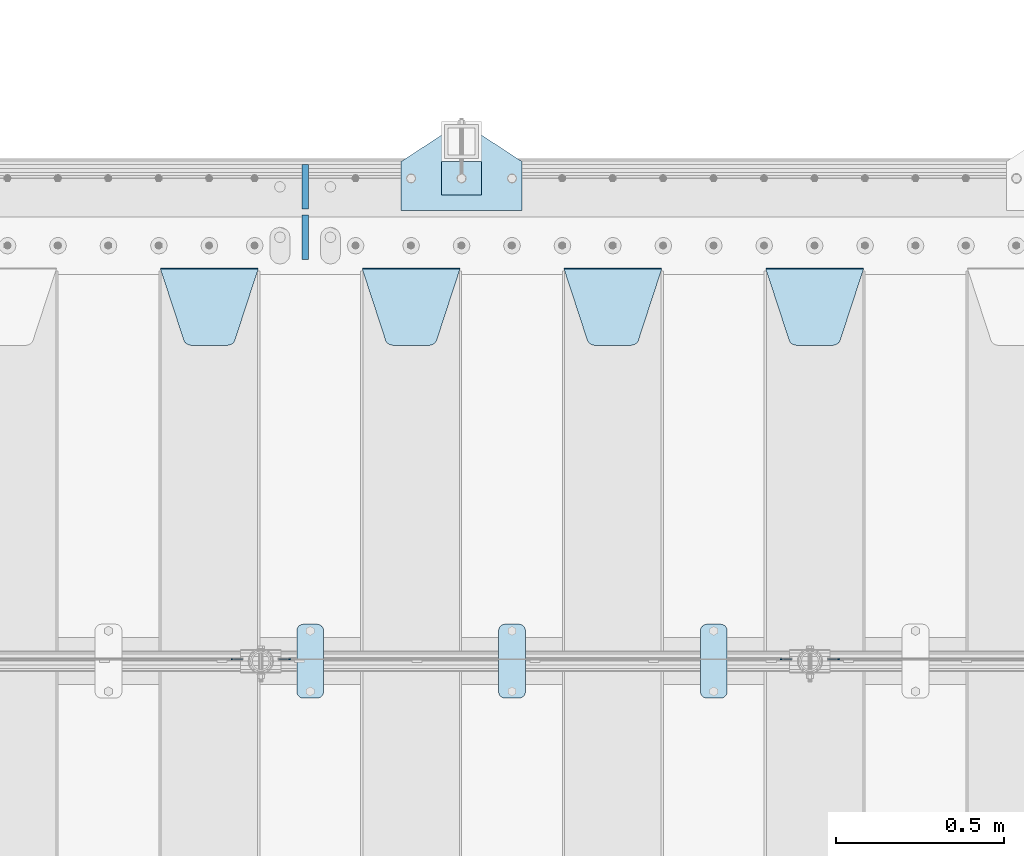
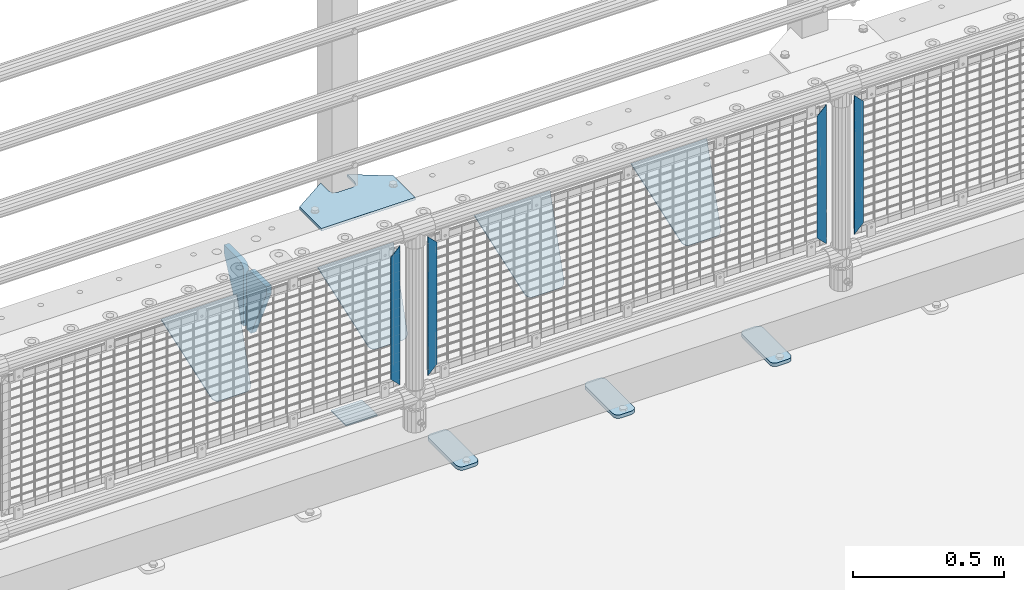
# One storey, part 234 of 270: 15 plates.
"""IFC2X3 building model written with IfcOpenShell, lengths in millimetres."""

from ifc_helpers import new_model, si_unit, frame, origin_with_axes, place, context, subcontext, project, spatial, faceted_brep, material, type_object, element, save


model = new_model("IFC2X3")

# Units and contexts
model_context = context("Model", 3, precision=1e-05, world=origin_with_axes())
body_context = subcontext(model_context, "Body", "Model", "MODEL_VIEW")
ifc_project = project(units=[si_unit("LENGTHUNIT", "METRE", prefix="MILLI"), si_unit("AREAUNIT", "SQUARE_METRE"), si_unit("VOLUMEUNIT", "CUBIC_METRE"), si_unit("MASSUNIT", "GRAM", prefix="KILO"), si_unit("TIMEUNIT", "SECOND"), si_unit("PLANEANGLEUNIT", "RADIAN"), si_unit("SOLIDANGLEUNIT", "STERADIAN"), si_unit("THERMODYNAMICTEMPERATUREUNIT", "DEGREE_CELSIUS"), si_unit("LUMINOUSINTENSITYUNIT", "LUMEN")], contexts=[model_context])

# Site, building, storey
site_placement = place(None, origin_with_axes())
site = spatial("IfcSite", under=ifc_project, at=site_placement, CompositionType="ELEMENT")
building_placement = place(site_placement, origin_with_axes())
building = spatial("IfcBuilding", under=site, at=building_placement, Name="Standard", CompositionType="ELEMENT")
storey_placement = place(building_placement, origin_with_axes())
storey = spatial("IfcBuildingStorey", under=building, at=storey_placement, Name="Undefined", CompositionType="ELEMENT", Elevation=0.0)

# Plates
ifc_material_1 = material(Name="STEEL/S355J2")
plate_type_1 = type_object("IfcPlateType", PredefinedType="NOTDEFINED")
plate_1_placement = place(storey_placement, frame((7570.0, -14995.0, 5.00000000004911), z_axis=(0.0, 1.0, 0.0), x_axis=(1.0, 0.0, 0.0)))
element("IfcPlate", 1, at=plate_1_placement, inside=storey, type_object=plate_type_1, material=ifc_material_1, context=body_context, shape_type="Brep", body=[
    faceted_brep([(0.0, -5.0, 0.0), (2.31396552408114e-06, -5.0, 145.0), (2.31396552408114e-06, 5.0, 145.0), (0.0, 5.0, 0.0), (130.0, -5.0, 230.0), (130.0, 5.0, 230.0), (130.0, -5.0, 180.0), (130.0, 5.0, 180.0), (130.48036798992, -5.0, 175.122741949597), (130.48036798992, 5.0, 175.122741949597), (131.903011687216, -5.0, 170.432914190873), (131.903011687216, 5.0, 170.432914190873), (134.213259692435, -5.0, 166.11074417451), (134.213259692435, 5.0, 166.11074417451), (137.322330470335, -5.0, 162.322330470337), (137.322330470335, 5.0, 162.322330470337), (141.110744174512, -5.0, 159.213259692437), (141.110744174512, 5.0, 159.213259692437), (145.432914190871, -5.0, 156.903011687218), (145.432914190871, 5.0, 156.903011687218), (150.122741949595, -5.0, 155.48036798992), (150.122741949595, 5.0, 155.48036798992), (155.0, -5.0, 155.0), (155.0, 5.0, 155.0), (205.0, -5.0, 155.0), (205.0, 5.0, 155.0), (209.877258050405, -5.0, 155.48036798992), (209.877258050405, 5.0, 155.48036798992), (214.567085809129, -5.0, 156.903011687218), (214.567085809129, 5.0, 156.903011687218), (218.889255825488, -5.0, 159.213259692437), (218.889255825488, 5.0, 159.213259692437), (222.677669529665, -5.0, 162.322330470337), (222.677669529665, 5.0, 162.322330470337), (225.786740307565, -5.0, 166.11074417451), (225.786740307565, 5.0, 166.11074417451), (228.096988312784, -5.0, 170.432914190873), (228.096988312784, 5.0, 170.432914190873), (229.51963201008, -5.0, 175.122741949597), (229.51963201008, 5.0, 175.122741949597), (230.0, -5.0, 180.0), (230.0, 5.0, 180.0), (230.0, -5.0, 230.0), (230.0, 5.0, 230.0), (360.0, -5.0, 145.0), (360.0, 5.0, 145.0), (360.0, -5.0, -7.27595761418343e-12), (360.0, 5.0, -7.27595761418343e-12)], [[[0, 1, 2, 3]], [[1, 4, 5, 2]], [[4, 6, 7, 5]], [[6, 8, 9, 7]], [[8, 10, 11, 9]], [[10, 12, 13, 11]], [[12, 14, 15, 13]], [[14, 16, 17, 15]], [[16, 18, 19, 17]], [[18, 20, 21, 19]], [[20, 22, 23, 21]], [[22, 24, 25, 23]], [[24, 26, 27, 25]], [[26, 28, 29, 27]], [[28, 30, 31, 29]], [[30, 32, 33, 31]], [[32, 34, 35, 33]], [[34, 36, 37, 35]], [[36, 38, 39, 37]], [[38, 40, 41, 39]], [[40, 42, 43, 41]], [[42, 44, 45, 43]], [[44, 46, 47, 45]], [[46, 0, 3, 47]], [[5, 7, 9, 11, 13, 15, 17, 19, 21, 23, 25, 27, 29, 31, 33, 35, 37, 39, 41, 43, 45, 47, 3, 2]], [[46, 44, 42, 40, 38, 36, 34, 32, 30, 28, 26, 24, 22, 20, 18, 16, 14, 12, 10, 8, 6, 4, 1, 0]]]),
])
plate_type_2 = type_object("IfcPlateType", PredefinedType="NOTDEFINED")
plate_2_placement = place(storey_placement, frame((7690.00000000014, -14949.9999999998, -857.500000000002), z_axis=(0.0, 1.0, 0.0), x_axis=(1.0, 0.0, 0.0)))
element("IfcPlate", 2, at=plate_2_placement, inside=storey, type_object=plate_type_2, material=ifc_material_1, context=body_context, shape_type="Brep", body=[
    faceted_brep([(0.0, -2.5, 0.0), (0.0, -2.5, 100.0), (0.0, 2.5, 100.0), (0.0, 2.5, 0.0), (120.0, -2.5, 100.0), (120.0, 2.5, 100.0), (120.0, -2.5, 0.0), (120.0, 2.5, 0.0)], [[[0, 1, 2, 3]], [[1, 4, 5, 2]], [[4, 6, 7, 5]], [[6, 0, 3, 7]], [[5, 7, 3, 2]], [[6, 4, 1, 0]]]),
])
plate_type_3 = type_object("IfcPlateType", PredefinedType="NOTDEFINED")
plate_3_placement = place(storey_placement, frame((8460.0, -16225.5, 21.0199999999977), z_axis=(1.0, 0.0, 0.0), x_axis=(0.0, -1.0, 0.0)))
element("IfcPlate", 3, at=plate_3_placement, inside=storey, type_object=plate_type_3, material=ifc_material_1, context=body_context, shape_type="Brep", body=[
    faceted_brep([(0.0, -7.0, 20.0), (0.0, -7.0, 60.0), (0.0, 7.0, 60.0), (0.0, 7.0, 20.0), (0.384294391937146, -7.0, 63.9018064403208), (0.384294391937146, 7.0, 63.9018064403208), (1.52240934977453, -7.0, 67.6536686473009), (1.52240934977453, 7.0, 67.6536686473009), (3.37060775395003, -7.0, 71.1114046603907), (3.37060775395003, 7.0, 71.1114046603907), (5.8578643762703, -7.0, 74.1421356237297), (5.8578643762703, 7.0, 74.1421356237297), (8.88859533960931, -7.0, 76.62939224605), (8.88859533960931, 7.0, 76.62939224605), (12.3463313526991, -7.0, 78.4775906502255), (12.3463313526991, 7.0, 78.4775906502255), (16.0981935596792, -7.0, 79.6157056080629), (16.0981935596792, 7.0, 79.6157056080629), (20.0, -7.0, 80.0), (20.0, 7.0, 80.0), (200.0, -7.0, 80.0), (200.0, 7.0, 80.0), (203.901806440321, -7.0, 79.6157056080629), (203.901806440321, 7.0, 79.6157056080629), (207.653668647301, -7.0, 78.4775906502255), (207.653668647301, 7.0, 78.4775906502255), (211.111404660391, -7.0, 76.62939224605), (211.111404660391, 7.0, 76.62939224605), (214.142135623733, -7.0, 74.1421356237297), (214.142135623733, 7.0, 74.1421356237297), (216.629392246054, -7.0, 71.1114046603907), (216.629392246054, 7.0, 71.1114046603907), (218.477590650225, -7.0, 67.6536686473009), (218.477590650225, 7.0, 67.6536686473009), (219.615705608063, -7.0, 63.9018064403208), (219.615705608063, 7.0, 63.9018064403208), (220.0, -7.0, 60.0), (220.0, 7.0, 60.0), (220.0, -7.0, 20.0), (220.0, 7.0, 20.0), (219.615705608063, -7.0, 16.0981935596792), (219.615705608063, 7.0, 16.0981935596792), (218.477590650225, -7.0, 12.3463313526991), (218.477590650225, 7.0, 12.3463313526991), (216.629392246054, -7.0, 8.88859533960931), (216.629392246054, 7.0, 8.88859533960931), (214.142135623733, -7.0, 5.8578643762703), (214.142135623733, 7.0, 5.8578643762703), (211.111404660391, -7.0, 3.37060775395003), (211.111404660391, 7.0, 3.37060775395003), (207.653668647301, -7.0, 1.52240934977453), (207.653668647301, 7.0, 1.52240934977453), (203.901806440321, -7.0, 0.384294391937146), (203.901806440321, 7.0, 0.384294391937146), (200.0, -7.0, 0.0), (200.0, 7.0, 0.0), (20.0, -7.0, 0.0), (20.0, 7.0, 0.0), (16.0981935596792, -7.0, 0.384294391937146), (16.0981935596792, 7.0, 0.384294391937146), (12.3463313526991, -7.0, 1.52240934977453), (12.3463313526991, 7.0, 1.52240934977453), (8.88859533960931, -7.0, 3.37060775395003), (8.88859533960931, 7.0, 3.37060775395003), (5.8578643762703, -7.0, 5.8578643762703), (5.8578643762703, 7.0, 5.8578643762703), (3.37060775395003, -7.0, 8.88859533960931), (3.37060775395003, 7.0, 8.88859533960931), (1.52240934977453, -7.0, 12.3463313526991), (1.52240934977453, 7.0, 12.3463313526991), (0.384294391937146, -7.0, 16.0981935596792), (0.384294391937146, 7.0, 16.0981935596792)], [[[0, 1, 2, 3]], [[1, 4, 5, 2]], [[4, 6, 7, 5]], [[6, 8, 9, 7]], [[8, 10, 11, 9]], [[10, 12, 13, 11]], [[12, 14, 15, 13]], [[14, 16, 17, 15]], [[16, 18, 19, 17]], [[18, 20, 21, 19]], [[20, 22, 23, 21]], [[22, 24, 25, 23]], [[24, 26, 27, 25]], [[26, 28, 29, 27]], [[28, 30, 31, 29]], [[30, 32, 33, 31]], [[32, 34, 35, 33]], [[34, 36, 37, 35]], [[36, 38, 39, 37]], [[38, 40, 41, 39]], [[40, 42, 43, 41]], [[42, 44, 45, 43]], [[44, 46, 47, 45]], [[46, 48, 49, 47]], [[48, 50, 51, 49]], [[50, 52, 53, 51]], [[52, 54, 55, 53]], [[54, 56, 57, 55]], [[56, 58, 59, 57]], [[58, 60, 61, 59]], [[60, 62, 63, 61]], [[62, 64, 65, 63]], [[64, 66, 67, 65]], [[66, 68, 69, 67]], [[68, 70, 71, 69]], [[70, 0, 3, 71]], [[5, 7, 9, 11, 13, 15, 17, 19, 21, 23, 25, 27, 29, 31, 33, 35, 37, 39, 41, 43, 45, 47, 49, 51, 53, 55, 57, 59, 61, 63, 65, 67, 69, 71, 3, 2]], [[70, 68, 66, 64, 62, 60, 58, 56, 54, 52, 50, 48, 46, 44, 42, 40, 38, 36, 34, 32, 30, 28, 26, 24, 22, 20, 18, 16, 14, 12, 10, 8, 6, 4, 1, 0]]]),
])
plate_4_placement = place(storey_placement, frame((7860.0, -16225.5, 21.0199999999977), z_axis=(1.0, 0.0, 0.0), x_axis=(0.0, -1.0, 0.0)))
element("IfcPlate", 4, at=plate_4_placement, inside=storey, type_object=plate_type_3, material=ifc_material_1, context=body_context, shape_type="Brep", body=[
    faceted_brep([(0.0, -7.0, 20.0), (0.0, -7.0, 60.0), (0.0, 7.0, 60.0), (0.0, 7.0, 20.0), (0.384294391937146, -7.0, 63.9018064403208), (0.384294391937146, 7.0, 63.9018064403208), (1.52240934977453, -7.0, 67.6536686473009), (1.52240934977453, 7.0, 67.6536686473009), (3.37060775395003, -7.0, 71.1114046603907), (3.37060775395003, 7.0, 71.1114046603907), (5.8578643762703, -7.0, 74.1421356237297), (5.8578643762703, 7.0, 74.1421356237297), (8.88859533960931, -7.0, 76.62939224605), (8.88859533960931, 7.0, 76.62939224605), (12.3463313526991, -7.0, 78.4775906502255), (12.3463313526991, 7.0, 78.4775906502255), (16.0981935596792, -7.0, 79.6157056080629), (16.0981935596792, 7.0, 79.6157056080629), (20.0, -7.0, 80.0), (20.0, 7.0, 80.0), (200.0, -7.0, 80.0), (200.0, 7.0, 80.0), (203.901806440321, -7.0, 79.6157056080629), (203.901806440321, 7.0, 79.6157056080629), (207.653668647301, -7.0, 78.4775906502255), (207.653668647301, 7.0, 78.4775906502255), (211.111404660391, -7.0, 76.62939224605), (211.111404660391, 7.0, 76.62939224605), (214.142135623733, -7.0, 74.1421356237297), (214.142135623733, 7.0, 74.1421356237297), (216.629392246054, -7.0, 71.1114046603907), (216.629392246054, 7.0, 71.1114046603907), (218.477590650225, -7.0, 67.6536686473009), (218.477590650225, 7.0, 67.6536686473009), (219.615705608063, -7.0, 63.9018064403208), (219.615705608063, 7.0, 63.9018064403208), (220.0, -7.0, 60.0), (220.0, 7.0, 60.0), (220.0, -7.0, 20.0), (220.0, 7.0, 20.0), (219.615705608063, -7.0, 16.0981935596792), (219.615705608063, 7.0, 16.0981935596792), (218.477590650225, -7.0, 12.3463313526991), (218.477590650225, 7.0, 12.3463313526991), (216.629392246054, -7.0, 8.88859533960931), (216.629392246054, 7.0, 8.88859533960931), (214.142135623733, -7.0, 5.8578643762703), (214.142135623733, 7.0, 5.8578643762703), (211.111404660391, -7.0, 3.37060775395003), (211.111404660391, 7.0, 3.37060775395003), (207.653668647301, -7.0, 1.52240934977453), (207.653668647301, 7.0, 1.52240934977453), (203.901806440321, -7.0, 0.384294391937146), (203.901806440321, 7.0, 0.384294391937146), (200.0, -7.0, 0.0), (200.0, 7.0, 0.0), (20.0, -7.0, 0.0), (20.0, 7.0, 0.0), (16.0981935596792, -7.0, 0.384294391937146), (16.0981935596792, 7.0, 0.384294391937146), (12.3463313526991, -7.0, 1.52240934977453), (12.3463313526991, 7.0, 1.52240934977453), (8.88859533960931, -7.0, 3.37060775395003), (8.88859533960931, 7.0, 3.37060775395003), (5.8578643762703, -7.0, 5.8578643762703), (5.8578643762703, 7.0, 5.8578643762703), (3.37060775395003, -7.0, 8.88859533960931), (3.37060775395003, 7.0, 8.88859533960931), (1.52240934977453, -7.0, 12.3463313526991), (1.52240934977453, 7.0, 12.3463313526991), (0.384294391937146, -7.0, 16.0981935596792), (0.384294391937146, 7.0, 16.0981935596792)], [[[0, 1, 2, 3]], [[1, 4, 5, 2]], [[4, 6, 7, 5]], [[6, 8, 9, 7]], [[8, 10, 11, 9]], [[10, 12, 13, 11]], [[12, 14, 15, 13]], [[14, 16, 17, 15]], [[16, 18, 19, 17]], [[18, 20, 21, 19]], [[20, 22, 23, 21]], [[22, 24, 25, 23]], [[24, 26, 27, 25]], [[26, 28, 29, 27]], [[28, 30, 31, 29]], [[30, 32, 33, 31]], [[32, 34, 35, 33]], [[34, 36, 37, 35]], [[36, 38, 39, 37]], [[38, 40, 41, 39]], [[40, 42, 43, 41]], [[42, 44, 45, 43]], [[44, 46, 47, 45]], [[46, 48, 49, 47]], [[48, 50, 51, 49]], [[50, 52, 53, 51]], [[52, 54, 55, 53]], [[54, 56, 57, 55]], [[56, 58, 59, 57]], [[58, 60, 61, 59]], [[60, 62, 63, 61]], [[62, 64, 65, 63]], [[64, 66, 67, 65]], [[66, 68, 69, 67]], [[68, 70, 71, 69]], [[70, 0, 3, 71]], [[5, 7, 9, 11, 13, 15, 17, 19, 21, 23, 25, 27, 29, 31, 33, 35, 37, 39, 41, 43, 45, 47, 49, 51, 53, 55, 57, 59, 61, 63, 65, 67, 69, 71, 3, 2]], [[70, 68, 66, 64, 62, 60, 58, 56, 54, 52, 50, 48, 46, 44, 42, 40, 38, 36, 34, 32, 30, 28, 26, 24, 22, 20, 18, 16, 14, 12, 10, 8, 6, 4, 1, 0]]]),
])
plate_5_placement = place(storey_placement, frame((7260.0, -16225.5, 21.0199999999977), z_axis=(1.0, 0.0, 0.0), x_axis=(0.0, -1.0, 0.0)))
element("IfcPlate", 5, at=plate_5_placement, inside=storey, type_object=plate_type_3, material=ifc_material_1, context=body_context, shape_type="Brep", body=[
    faceted_brep([(0.0, -7.0, 20.0), (0.0, -7.0, 60.0), (0.0, 7.0, 60.0), (0.0, 7.0, 20.0), (0.384294391937146, -7.0, 63.9018064403208), (0.384294391937146, 7.0, 63.9018064403208), (1.52240934977453, -7.0, 67.6536686473009), (1.52240934977453, 7.0, 67.6536686473009), (3.37060775395003, -7.0, 71.1114046603907), (3.37060775395003, 7.0, 71.1114046603907), (5.8578643762703, -7.0, 74.1421356237297), (5.8578643762703, 7.0, 74.1421356237297), (8.88859533960931, -7.0, 76.62939224605), (8.88859533960931, 7.0, 76.62939224605), (12.3463313526991, -7.0, 78.4775906502255), (12.3463313526991, 7.0, 78.4775906502255), (16.0981935596792, -7.0, 79.6157056080629), (16.0981935596792, 7.0, 79.6157056080629), (20.0, -7.0, 80.0), (20.0, 7.0, 80.0), (200.0, -7.0, 80.0), (200.0, 7.0, 80.0), (203.901806440321, -7.0, 79.6157056080629), (203.901806440321, 7.0, 79.6157056080629), (207.653668647301, -7.0, 78.4775906502255), (207.653668647301, 7.0, 78.4775906502255), (211.111404660391, -7.0, 76.62939224605), (211.111404660391, 7.0, 76.62939224605), (214.142135623733, -7.0, 74.1421356237297), (214.142135623733, 7.0, 74.1421356237297), (216.629392246054, -7.0, 71.1114046603907), (216.629392246054, 7.0, 71.1114046603907), (218.477590650225, -7.0, 67.6536686473009), (218.477590650225, 7.0, 67.6536686473009), (219.615705608063, -7.0, 63.9018064403208), (219.615705608063, 7.0, 63.9018064403208), (220.0, -7.0, 60.0), (220.0, 7.0, 60.0), (220.0, -7.0, 20.0), (220.0, 7.0, 20.0), (219.615705608063, -7.0, 16.0981935596792), (219.615705608063, 7.0, 16.0981935596792), (218.477590650225, -7.0, 12.3463313526991), (218.477590650225, 7.0, 12.3463313526991), (216.629392246054, -7.0, 8.88859533960931), (216.629392246054, 7.0, 8.88859533960931), (214.142135623733, -7.0, 5.8578643762703), (214.142135623733, 7.0, 5.8578643762703), (211.111404660391, -7.0, 3.37060775395003), (211.111404660391, 7.0, 3.37060775395003), (207.653668647301, -7.0, 1.52240934977453), (207.653668647301, 7.0, 1.52240934977453), (203.901806440321, -7.0, 0.384294391937146), (203.901806440321, 7.0, 0.384294391937146), (200.0, -7.0, 0.0), (200.0, 7.0, 0.0), (20.0, -7.0, 0.0), (20.0, 7.0, 0.0), (16.0981935596792, -7.0, 0.384294391937146), (16.0981935596792, 7.0, 0.384294391937146), (12.3463313526991, -7.0, 1.52240934977453), (12.3463313526991, 7.0, 1.52240934977453), (8.88859533960931, -7.0, 3.37060775395003), (8.88859533960931, 7.0, 3.37060775395003), (5.8578643762703, -7.0, 5.8578643762703), (5.8578643762703, 7.0, 5.8578643762703), (3.37060775395003, -7.0, 8.88859533960931), (3.37060775395003, 7.0, 8.88859533960931), (1.52240934977453, -7.0, 12.3463313526991), (1.52240934977453, 7.0, 12.3463313526991), (0.384294391937146, -7.0, 16.0981935596792), (0.384294391937146, 7.0, 16.0981935596792)], [[[0, 1, 2, 3]], [[1, 4, 5, 2]], [[4, 6, 7, 5]], [[6, 8, 9, 7]], [[8, 10, 11, 9]], [[10, 12, 13, 11]], [[12, 14, 15, 13]], [[14, 16, 17, 15]], [[16, 18, 19, 17]], [[18, 20, 21, 19]], [[20, 22, 23, 21]], [[22, 24, 25, 23]], [[24, 26, 27, 25]], [[26, 28, 29, 27]], [[28, 30, 31, 29]], [[30, 32, 33, 31]], [[32, 34, 35, 33]], [[34, 36, 37, 35]], [[36, 38, 39, 37]], [[38, 40, 41, 39]], [[40, 42, 43, 41]], [[42, 44, 45, 43]], [[44, 46, 47, 45]], [[46, 48, 49, 47]], [[48, 50, 51, 49]], [[50, 52, 53, 51]], [[52, 54, 55, 53]], [[54, 56, 57, 55]], [[56, 58, 59, 57]], [[58, 60, 61, 59]], [[60, 62, 63, 61]], [[62, 64, 65, 63]], [[64, 66, 67, 65]], [[66, 68, 69, 67]], [[68, 70, 71, 69]], [[70, 0, 3, 71]], [[5, 7, 9, 11, 13, 15, 17, 19, 21, 23, 25, 27, 29, 31, 33, 35, 37, 39, 41, 43, 45, 47, 49, 51, 53, 55, 57, 59, 61, 63, 65, 67, 69, 71, 3, 2]], [[70, 68, 66, 64, 62, 60, 58, 56, 54, 52, 50, 48, 46, 44, 42, 40, 38, 36, 34, 32, 30, 28, 26, 24, 22, 20, 18, 16, 14, 12, 10, 8, 6, 4, 1, 0]]]),
])
ifc_material_2 = material(Name="STEEL/S355N")
plate_type_4 = type_object("IfcPlateType", PredefinedType="NOTDEFINED")
plate_6_placement = place(storey_placement, frame((8655.0, -15168.2322330441, -1.76776695296576), z_axis=(0.0, -0.707106781186548, -0.707106781186547), x_axis=(1.0, 0.0, 0.0)))
element("IfcPlate", 6, at=plate_6_placement, inside=storey, type_object=plate_type_4, material=ifc_material_2, context=body_context, shape_type="Brep", body=[
    faceted_brep([(0.0, -2.5, 0.0), (69.345504679477, -2.5, 300.171731424831), (69.345504679477, 2.5, 300.171731424831), (0.0, 2.5, 0.0), (70.9274061199576, -2.5, 304.8974424154), (70.9274061199576, 2.5, 304.8974424154), (73.3818627772307, -2.49999999999818, 309.234538108527), (73.3818627772307, 2.50000000000182, 309.234538108527), (76.6187032999551, -2.5, 313.023683126103), (76.6187032999551, 2.5, 313.023683126103), (80.5190132704993, -2.5, 316.125672595372), (80.5190132704993, 2.50000000000182, 316.125672595372), (84.9395038596849, -2.49999999999818, 318.426546230476), (84.9395038596849, 2.5, 318.426546230476), (89.7177759439219, -2.49999999999818, 319.841774983275), (89.7177759439219, 2.50000000000182, 319.841774983275), (94.678286292652, -2.5, 320.319366455078), (94.678286292652, 2.5, 320.319366455078), (195.321713707348, -2.5, 320.319366455078), (195.321713707348, 2.5, 320.319366455078), (200.282224056078, -2.49999999999818, 319.841774983275), (200.282224056078, 2.50000000000182, 319.841774983275), (205.060496140315, -2.5, 318.426546230476), (205.060496140315, 2.5, 318.426546230476), (209.480986729501, -2.5, 316.12567259537), (209.480986729501, 2.50000000000182, 316.12567259537), (213.381296700045, -2.5, 313.023683126103), (213.381296700045, 2.5, 313.023683126103), (216.618137222769, -2.49999999999818, 309.234538108525), (216.618137222769, 2.50000000000182, 309.234538108527), (219.072593880042, -2.49999999999818, 304.897442415398), (219.072593880042, 2.50000000000182, 304.897442415397), (220.654495320523, -2.5, 300.171731424831), (220.654495320523, 2.5, 300.171731424831), (290.0, -2.49999999999818, 0.0), (290.0, 2.5, 0.0)], [[[0, 1, 2, 3]], [[1, 4, 5, 2]], [[4, 6, 7, 5]], [[6, 8, 9, 7]], [[8, 10, 11, 9]], [[10, 12, 13, 11]], [[12, 14, 15, 13]], [[14, 16, 17, 15]], [[16, 18, 19, 17]], [[18, 20, 21, 19]], [[20, 22, 23, 21]], [[22, 24, 25, 23]], [[24, 26, 27, 25]], [[26, 28, 29, 27]], [[28, 30, 31, 29]], [[30, 32, 33, 31]], [[32, 34, 35, 33]], [[34, 0, 3, 35]], [[5, 7, 9, 11, 13, 15, 17, 19, 21, 23, 25, 27, 29, 31, 33, 35, 3, 2]], [[34, 32, 30, 28, 26, 24, 22, 20, 18, 16, 14, 12, 10, 8, 6, 4, 1, 0]]]),
])
plate_7_placement = place(storey_placement, frame((8055.0, -15168.2322330441, -1.76776695296576), z_axis=(0.0, -0.707106781186548, -0.707106781186547), x_axis=(1.0, 0.0, 0.0)))
element("IfcPlate", 7, at=plate_7_placement, inside=storey, type_object=plate_type_4, material=ifc_material_2, context=body_context, shape_type="Brep", body=[
    faceted_brep([(0.0, -2.5, 0.0), (69.345504679477, -2.5, 300.171731424831), (69.345504679477, 2.5, 300.171731424831), (0.0, 2.5, 0.0), (70.9274061199576, -2.5, 304.8974424154), (70.9274061199576, 2.5, 304.8974424154), (73.3818627772307, -2.49999999999818, 309.234538108527), (73.3818627772307, 2.50000000000182, 309.234538108527), (76.6187032999551, -2.5, 313.023683126103), (76.6187032999551, 2.5, 313.023683126103), (80.5190132704993, -2.5, 316.125672595372), (80.5190132704993, 2.50000000000182, 316.125672595372), (84.9395038596849, -2.49999999999818, 318.426546230476), (84.9395038596849, 2.5, 318.426546230476), (89.7177759439219, -2.49999999999818, 319.841774983275), (89.7177759439219, 2.50000000000182, 319.841774983275), (94.678286292652, -2.5, 320.319366455078), (94.678286292652, 2.5, 320.319366455078), (195.321713707348, -2.5, 320.319366455078), (195.321713707348, 2.5, 320.319366455078), (200.282224056078, -2.49999999999818, 319.841774983275), (200.282224056078, 2.50000000000182, 319.841774983275), (205.060496140315, -2.5, 318.426546230476), (205.060496140315, 2.5, 318.426546230476), (209.480986729501, -2.5, 316.12567259537), (209.480986729501, 2.50000000000182, 316.12567259537), (213.381296700045, -2.5, 313.023683126103), (213.381296700045, 2.5, 313.023683126103), (216.618137222769, -2.49999999999818, 309.234538108525), (216.618137222769, 2.50000000000182, 309.234538108527), (219.072593880042, -2.49999999999818, 304.897442415398), (219.072593880042, 2.50000000000182, 304.897442415397), (220.654495320523, -2.5, 300.171731424831), (220.654495320523, 2.5, 300.171731424831), (290.0, -2.49999999999818, 0.0), (290.0, 2.5, 0.0)], [[[0, 1, 2, 3]], [[1, 4, 5, 2]], [[4, 6, 7, 5]], [[6, 8, 9, 7]], [[8, 10, 11, 9]], [[10, 12, 13, 11]], [[12, 14, 15, 13]], [[14, 16, 17, 15]], [[16, 18, 19, 17]], [[18, 20, 21, 19]], [[20, 22, 23, 21]], [[22, 24, 25, 23]], [[24, 26, 27, 25]], [[26, 28, 29, 27]], [[28, 30, 31, 29]], [[30, 32, 33, 31]], [[32, 34, 35, 33]], [[34, 0, 3, 35]], [[5, 7, 9, 11, 13, 15, 17, 19, 21, 23, 25, 27, 29, 31, 33, 35, 3, 2]], [[34, 32, 30, 28, 26, 24, 22, 20, 18, 16, 14, 12, 10, 8, 6, 4, 1, 0]]]),
])
plate_8_placement = place(storey_placement, frame((7455.0, -15168.2322330441, -1.76776695296576), z_axis=(0.0, -0.707106781186548, -0.707106781186547), x_axis=(1.0, 0.0, 0.0)))
element("IfcPlate", 8, at=plate_8_placement, inside=storey, type_object=plate_type_4, material=ifc_material_2, context=body_context, shape_type="Brep", body=[
    faceted_brep([(0.0, -2.5, 0.0), (69.345504679477, -2.5, 300.171731424831), (69.345504679477, 2.5, 300.171731424831), (0.0, 2.5, 0.0), (70.9274061199576, -2.5, 304.8974424154), (70.9274061199576, 2.5, 304.8974424154), (73.3818627772307, -2.49999999999818, 309.234538108527), (73.3818627772307, 2.50000000000182, 309.234538108527), (76.6187032999551, -2.5, 313.023683126103), (76.6187032999551, 2.5, 313.023683126103), (80.5190132704993, -2.5, 316.125672595372), (80.5190132704993, 2.50000000000182, 316.125672595372), (84.9395038596849, -2.49999999999818, 318.426546230476), (84.9395038596849, 2.5, 318.426546230476), (89.7177759439219, -2.49999999999818, 319.841774983275), (89.7177759439219, 2.50000000000182, 319.841774983275), (94.678286292652, -2.5, 320.319366455078), (94.678286292652, 2.5, 320.319366455078), (195.321713707348, -2.5, 320.319366455078), (195.321713707348, 2.5, 320.319366455078), (200.282224056078, -2.49999999999818, 319.841774983275), (200.282224056078, 2.50000000000182, 319.841774983275), (205.060496140315, -2.5, 318.426546230476), (205.060496140315, 2.5, 318.426546230476), (209.480986729501, -2.5, 316.12567259537), (209.480986729501, 2.50000000000182, 316.12567259537), (213.381296700045, -2.5, 313.023683126103), (213.381296700045, 2.5, 313.023683126103), (216.618137222769, -2.49999999999818, 309.234538108525), (216.618137222769, 2.50000000000182, 309.234538108527), (219.072593880042, -2.49999999999818, 304.897442415398), (219.072593880042, 2.50000000000182, 304.897442415397), (220.654495320523, -2.5, 300.171731424831), (220.654495320523, 2.5, 300.171731424831), (290.0, -2.49999999999818, 0.0), (290.0, 2.5, 0.0)], [[[0, 1, 2, 3]], [[1, 4, 5, 2]], [[4, 6, 7, 5]], [[6, 8, 9, 7]], [[8, 10, 11, 9]], [[10, 12, 13, 11]], [[12, 14, 15, 13]], [[14, 16, 17, 15]], [[16, 18, 19, 17]], [[18, 20, 21, 19]], [[20, 22, 23, 21]], [[22, 24, 25, 23]], [[24, 26, 27, 25]], [[26, 28, 29, 27]], [[28, 30, 31, 29]], [[30, 32, 33, 31]], [[32, 34, 35, 33]], [[34, 0, 3, 35]], [[5, 7, 9, 11, 13, 15, 17, 19, 21, 23, 25, 27, 29, 31, 33, 35, 3, 2]], [[34, 32, 30, 28, 26, 24, 22, 20, 18, 16, 14, 12, 10, 8, 6, 4, 1, 0]]]),
])
plate_9_placement = place(storey_placement, frame((6855.0, -15168.2322330441, -1.76776695296576), z_axis=(0.0, -0.707106781186548, -0.707106781186547), x_axis=(1.0, 0.0, 0.0)))
element("IfcPlate", 9, at=plate_9_placement, inside=storey, type_object=plate_type_4, material=ifc_material_2, context=body_context, shape_type="Brep", body=[
    faceted_brep([(0.0, -2.5, 0.0), (69.345504679477, -2.5, 300.171731424831), (69.345504679477, 2.5, 300.171731424831), (0.0, 2.5, 0.0), (70.9274061199576, -2.5, 304.8974424154), (70.9274061199576, 2.5, 304.8974424154), (73.3818627772307, -2.49999999999818, 309.234538108527), (73.3818627772307, 2.50000000000182, 309.234538108527), (76.6187032999551, -2.5, 313.023683126103), (76.6187032999551, 2.5, 313.023683126103), (80.5190132704993, -2.5, 316.125672595372), (80.5190132704993, 2.50000000000182, 316.125672595372), (84.9395038596849, -2.49999999999818, 318.426546230476), (84.9395038596849, 2.5, 318.426546230476), (89.7177759439219, -2.49999999999818, 319.841774983275), (89.7177759439219, 2.50000000000182, 319.841774983275), (94.678286292652, -2.5, 320.319366455078), (94.678286292652, 2.5, 320.319366455078), (195.321713707348, -2.5, 320.319366455078), (195.321713707348, 2.5, 320.319366455078), (200.282224056078, -2.49999999999818, 319.841774983275), (200.282224056078, 2.50000000000182, 319.841774983275), (205.060496140315, -2.5, 318.426546230476), (205.060496140315, 2.5, 318.426546230476), (209.480986729501, -2.5, 316.12567259537), (209.480986729501, 2.50000000000182, 316.12567259537), (213.381296700045, -2.5, 313.023683126103), (213.381296700045, 2.5, 313.023683126103), (216.618137222769, -2.49999999999818, 309.234538108525), (216.618137222769, 2.50000000000182, 309.234538108527), (219.072593880042, -2.49999999999818, 304.897442415398), (219.072593880042, 2.50000000000182, 304.897442415397), (220.654495320523, -2.5, 300.171731424831), (220.654495320523, 2.5, 300.171731424831), (290.0, -2.49999999999818, 0.0), (290.0, 2.5, 0.0)], [[[0, 1, 2, 3]], [[1, 4, 5, 2]], [[4, 6, 7, 5]], [[6, 8, 9, 7]], [[8, 10, 11, 9]], [[10, 12, 13, 11]], [[12, 14, 15, 13]], [[14, 16, 17, 15]], [[16, 18, 19, 17]], [[18, 20, 21, 19]], [[20, 22, 23, 21]], [[22, 24, 25, 23]], [[24, 26, 27, 25]], [[26, 28, 29, 27]], [[28, 30, 31, 29]], [[30, 32, 33, 31]], [[32, 34, 35, 33]], [[34, 0, 3, 35]], [[5, 7, 9, 11, 13, 15, 17, 19, 21, 23, 25, 27, 29, 31, 33, 35, 3, 2]], [[34, 32, 30, 28, 26, 24, 22, 20, 18, 16, 14, 12, 10, 8, 6, 4, 1, 0]]]),
])
ifc_material_3 = material(Name="Misc_Undefined")
plate_type_5 = type_object("IfcPlateType", PredefinedType="NOTDEFINED")
for number, where, z_axis, x_axis in (
    (10, (8874.50971354097, -16329.5, 879.519963133601), (-0.707008801899319, 0.0, -0.707204746899291), (-0.707204746899302, 0.0, 0.707008801899308)),
    (11, (7241.50971354097, -16329.5, 879.519963133601), (-0.707008801899319, 0.0, -0.707204746899291), (-0.707204746899302, 0.0, 0.707008801899308)),
):
    element("IfcPlate", number, at=place(storey_placement, frame(where, z_axis=z_axis, x_axis=x_axis)), inside=storey, type_object=plate_type_5, material=ifc_material_3, context=body_context, shape_type="Brep", body=[
        faceted_brep([(0.0, -1.5, 0.0), (-348.552185058599, -1.5, 348.655029296877), (-348.552185058599, 1.5, 348.655029296877), (0.0, 1.5, 0.0), (-348.544891357427, -1.5, 398.152496337894), (-348.544891357427, 1.5, 398.152496337894), (49.50439453125, -1.5, 8.00355337560177e-11), (49.50439453125, 1.5, 8.00355337560177e-11)], [[[0, 1, 2, 3]], [[1, 4, 5, 2]], [[4, 6, 7, 5]], [[6, 0, 3, 7]], [[5, 7, 3, 2]], [[6, 4, 1, 0]]]),
    ])
for number, where, z_axis, x_axis in (
    (12, (8697.49968748361, -16329.5, 879.52), (0.707103624179499, 0.0, -0.707109938179501), (0.707109938179513, 0.0, 0.707103624179487)),
    (13, (7064.49968748361, -16329.5, 879.52), (0.707103624179499, 0.0, -0.707109938179501), (0.707109938179513, 0.0, 0.707103624179487)),
):
    element("IfcPlate", number, at=place(storey_placement, frame(where, z_axis=z_axis, x_axis=x_axis)), inside=storey, type_object=plate_type_5, material=ifc_material_3, context=body_context, shape_type="Brep", body=[
        faceted_brep([(0.0, -1.5, 0.0), (-348.605163574224, -1.5, 348.602081298828), (-348.605163574224, 1.5, 348.602081298828), (0.0, 1.5, 0.0), (-348.605163574226, -1.5, 398.099334716795), (-348.605163574226, 1.5, 398.099334716795), (49.4976959228497, -1.5, -7.27595761418343e-12), (49.4976959228497, 1.5, -7.27595761418343e-12)], [[[0, 1, 2, 3]], [[1, 4, 5, 2]], [[4, 6, 7, 5]], [[6, 0, 3, 7]], [[5, 7, 3, 2]], [[6, 4, 1, 0]]]),
    ])
plate_type_6 = type_object("IfcPlateType", PredefinedType="NOTDEFINED")
for number, where, z_axis, x_axis in (
    (14, (7285.0, -14858.75, -35.0), (0.0, 0.0, -1.0), (0.0, -1.0, 0.0)),
    (15, (7285.0, -15141.25, -35.0), (0.0, 0.0, -1.0), (0.0, 1.0, 0.0)),
):
    element("IfcPlate", number, at=place(storey_placement, frame(where, z_axis=z_axis, x_axis=x_axis)), inside=storey, type_object=plate_type_6, material=ifc_material_2, context=body_context, shape_type="Brep", body=[
        faceted_brep([(0.0, -10.0, 0.0), (0.0, -10.0, 30.0), (0.0, 10.0, 30.0), (0.0, 10.0, 0.0), (102.0, -10.0, 250.0), (102.0, 10.0, 250.0), (132.0, -10.0, 250.0), (132.0, 10.0, 250.0), (132.0, -10.0, 30.0), (132.0, 10.0, 30.0), (131.544232590368, -10.0, 24.790554669992), (131.544232590368, 10.0, 24.790554669992), (130.190778623579, -10.0, 19.7393957002299), (130.190778623579, 10.0, 19.7393957002299), (127.980762113533, -10.0, 15.0), (127.980762113533, 10.0, 15.0), (124.98133329357, -10.0, 10.7163717094038), (124.98133329357, 10.0, 10.7163717094038), (121.283628290596, -10.0, 7.01866670643062), (121.283628290596, 10.0, 7.01866670643062), (117.0, -10.0, 4.01923788646684), (117.0, 10.0, 4.01923788646684), (112.260604299769, -10.0, 1.80922137642278), (112.260604299769, 10.0, 1.80922137642278), (107.209445330009, -10.0, 0.455767409633722), (107.209445330009, 10.0, 0.455767409633722), (102.0, -10.0, 0.0), (102.0, 10.0, 0.0)], [[[0, 1, 2, 3]], [[1, 4, 5, 2]], [[4, 6, 7, 5]], [[6, 8, 9, 7]], [[8, 10, 11, 9]], [[10, 12, 13, 11]], [[12, 14, 15, 13]], [[14, 16, 17, 15]], [[16, 18, 19, 17]], [[18, 20, 21, 19]], [[20, 22, 23, 21]], [[22, 24, 25, 23]], [[24, 26, 27, 25]], [[26, 0, 3, 27]], [[5, 7, 9, 11, 13, 15, 17, 19, 21, 23, 25, 27, 3, 2]], [[26, 24, 22, 20, 18, 16, 14, 12, 10, 8, 6, 4, 1, 0]]]),
    ])

save(model, "model.ifc")
